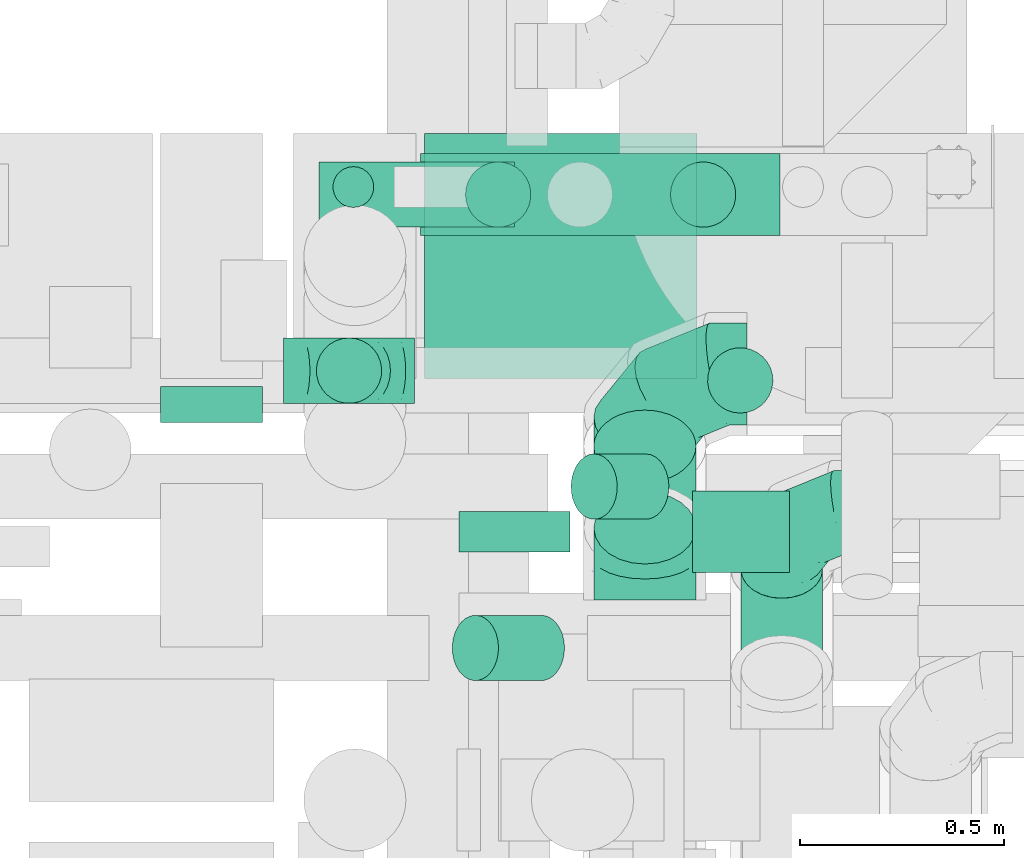
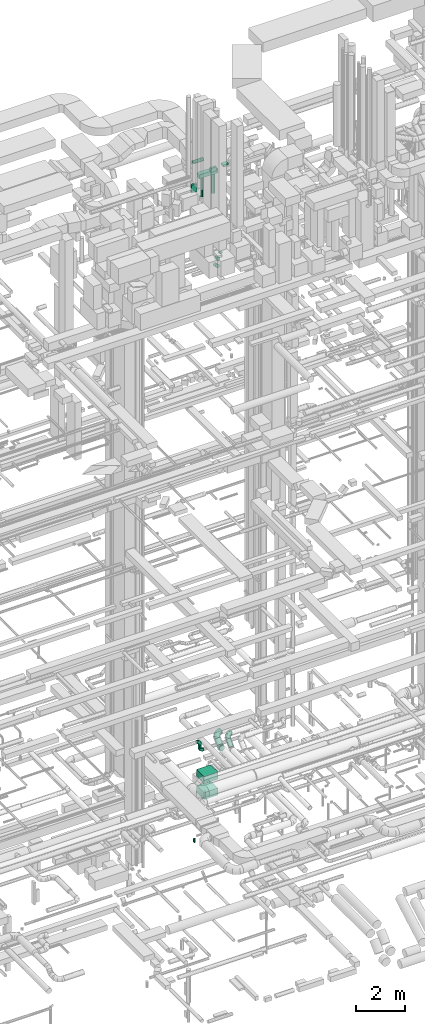
# One storey, part 189 of 337: 16 flow segments, 5 flow fittings.
"""IFC2X3 building model written with IfcOpenShell, lengths in millimetres."""

from ifc_helpers import new_model, entity, si_unit, converted_unit, derived_unit, direction, frame, origin, origin_2d_with_axis, place, context, subcontext, project, spatial, rectangle, circle, extrude, faceted_brep, source, transform, mapped, material, type_object, type_shapes, element, save


model = new_model("IFC2X3")

# Units and contexts
model_context = context("Model", 3, precision=0.01, world=origin(), true_north=direction((6.12303176911189e-17, 1.0)))
body_context = subcontext(model_context, "Body", "Model", "MODEL_VIEW")
ifc_project = project(units=[si_unit("LENGTHUNIT", "METRE", prefix="MILLI"), si_unit("AREAUNIT", "SQUARE_METRE"), si_unit("VOLUMEUNIT", "CUBIC_METRE"), converted_unit("PLANEANGLEUNIT", "DEGREE", entity("IfcRatioMeasure", 0.0174532925199433), si_unit("PLANEANGLEUNIT", "RADIAN"), dimensions=[0, 0, 0, 0, 0, 0, 0]), si_unit("MASSUNIT", "GRAM", prefix="KILO"), derived_unit("MASSDENSITYUNIT", [(si_unit("MASSUNIT", "GRAM", prefix="KILO"), 1), (si_unit("LENGTHUNIT", "METRE"), -3)]), derived_unit("MOMENTOFINERTIAUNIT", [(si_unit("LENGTHUNIT", "METRE"), 4)]), si_unit("TIMEUNIT", "SECOND"), si_unit("FREQUENCYUNIT", "HERTZ"), si_unit("THERMODYNAMICTEMPERATUREUNIT", "DEGREE_CELSIUS"), derived_unit("THERMALTRANSMITTANCEUNIT", [(si_unit("MASSUNIT", "GRAM", prefix="KILO"), 1), (si_unit("THERMODYNAMICTEMPERATUREUNIT", "KELVIN"), -1), (si_unit("TIMEUNIT", "SECOND"), -3)]), derived_unit("VOLUMETRICFLOWRATEUNIT", [(si_unit("LENGTHUNIT", "METRE"), 3), (si_unit("TIMEUNIT", "SECOND"), -1)]), derived_unit("MASSFLOWRATEUNIT", [(si_unit("MASSUNIT", "GRAM", prefix="KILO"), 1), (si_unit("TIMEUNIT", "SECOND"), -1)]), derived_unit("ROTATIONALFREQUENCYUNIT", [(si_unit("TIMEUNIT", "SECOND"), -1)]), si_unit("ELECTRICCURRENTUNIT", "AMPERE"), si_unit("ELECTRICVOLTAGEUNIT", "VOLT"), si_unit("POWERUNIT", "WATT"), si_unit("FORCEUNIT", "NEWTON", prefix="KILO"), si_unit("ILLUMINANCEUNIT", "LUX"), si_unit("LUMINOUSFLUXUNIT", "LUMEN"), si_unit("LUMINOUSINTENSITYUNIT", "CANDELA"), derived_unit("USERDEFINED", [(si_unit("MASSUNIT", "GRAM", prefix="KILO"), -1), (si_unit("LENGTHUNIT", "METRE"), -2), (si_unit("TIMEUNIT", "SECOND"), 3), (si_unit("LUMINOUSFLUXUNIT", "LUMEN"), 1)]), derived_unit("LINEARVELOCITYUNIT", [(si_unit("LENGTHUNIT", "METRE"), 1), (si_unit("TIMEUNIT", "SECOND"), -1)]), si_unit("PRESSUREUNIT", "PASCAL"), derived_unit("USERDEFINED", [(si_unit("LENGTHUNIT", "METRE"), -2), (si_unit("MASSUNIT", "GRAM", prefix="KILO"), 1), (si_unit("TIMEUNIT", "SECOND"), -2)]), derived_unit("LINEARFORCEUNIT", [(si_unit("MASSUNIT", "GRAM", prefix="KILO"), 1), (si_unit("LENGTHUNIT", "METRE"), 1), (si_unit("TIMEUNIT", "SECOND"), -2), (si_unit("LENGTHUNIT", "METRE"), -1)]), derived_unit("PLANARFORCEUNIT", [(si_unit("MASSUNIT", "GRAM", prefix="KILO"), 1), (si_unit("LENGTHUNIT", "METRE"), 1), (si_unit("TIMEUNIT", "SECOND"), -2), (si_unit("LENGTHUNIT", "METRE"), -2)])], contexts=[model_context])

# Site, building, storey
site_placement = place(None, origin())
site = spatial("IfcSite", under=ifc_project, at=site_placement, CompositionType="ELEMENT")
building_placement = place(site_placement, origin())
building = spatial("IfcBuilding", under=site, at=building_placement, CompositionType="ELEMENT")
storey_placement = place(building_placement, origin())
storey = spatial("IfcBuildingStorey", under=building, at=storey_placement, CompositionType="ELEMENT", Elevation=0.0)

# Flow segments
duct_segment_type_1 = type_object("IfcDuctSegmentType", PredefinedType="NOTDEFINED")
for number, where in (
    (1, (49187.58, 12574.75, 300.06)),
    (2, (49187.58, 12574.75, 1100.06)),
):
    element("IfcFlowSegment", number, at=place(storey_placement, frame(where)), inside=storey, type_object=duct_segment_type_1, context=body_context, shape_type="SweptSolid", body=[
        extrude(rectangle(XDim=666.974171799962, YDim=600.0, at=origin_2d_with_axis()), frame((333.49, 300.0, 0.0), z_axis=(0.0, 0.0, 1.0), x_axis=(-1.0, 0.0, 0.0)), (0.0, 0.0, 1.0), 350.0),
    ])
flow_segment_1_placement = place(storey_placement, frame((49178.28, 12924.99, 30999.32)))
element("IfcFlowSegment", 3, at=flow_segment_1_placement, inside=storey, type_object=duct_segment_type_1, context=body_context, shape_type="SweptSolid", body=[
    extrude(rectangle(XDim=879.999999999939, YDim=200.0, at=origin_2d_with_axis()), frame((440.0, 100.0, 0.0), z_axis=(0.0, 0.0, 1.0), x_axis=(-1.0, 0.0, 0.0)), (0.0, 0.0, 1.0), 199.999999999998),
])
flow_segment_2_placement = place(storey_placement, frame((48542.04, 12467.5, 30780.0)))
element("IfcFlowSegment", 4, at=flow_segment_2_placement, inside=storey, type_object=duct_segment_type_1, context=body_context, shape_type="SweptSolid", body=[
    extrude(rectangle(XDim=87.2484350000335, YDim=250.000000000004, at=origin_2d_with_axis()), frame((125.0, 43.62, 0.0), z_axis=(0.0, 0.0, 1.0), x_axis=(0.0, -1.0, 0.0)), (0.0, 0.0, 1.0), 400.000000000004),
])
flow_segment_3_placement = place(storey_placement, frame((49273.0, 12149.48, 31750.0)))
element("IfcFlowSegment", 5, at=flow_segment_3_placement, inside=storey, type_object=duct_segment_type_1, context=body_context, shape_type="SweptSolid", body=[
    extrude(rectangle(XDim=271.034502525399, YDim=100.000000000001, at=origin_2d_with_axis()), frame((135.52, 50.0, 0.0)), (0.0, 0.0, 1.0), 199.999999999998),
])
flow_segment_4_placement = place(storey_placement, frame((49844.03, 12099.48, 31850.0)))
element("IfcFlowSegment", 6, at=flow_segment_4_placement, inside=storey, type_object=duct_segment_type_1, context=body_context, shape_type="SweptSolid", body=[
    extrude(rectangle(XDim=237.021317421704, YDim=200.0, at=origin_2d_with_axis()), frame((118.51, 100.0, 0.0), z_axis=(0.0, 0.0, 1.0), x_axis=(-1.0, 0.0, 0.0)), (0.0, 0.0, 1.0), 100.000000000003),
])
duct_segment_type_2 = type_object("IfcDuctSegmentType", PredefinedType="NOTDEFINED")
flow_segment_5_placement = place(storey_placement, frame((49545.32, 12228.45, 27128.7)))
element("IfcFlowSegment", 7, at=flow_segment_5_placement, inside=storey, type_object=duct_segment_type_2, context=body_context, shape_type="SweptSolid", body=[
    extrude(circle(Radius=80.0, at=origin_2d_with_axis()), frame((184.44, 81.6, 58.16), z_axis=(-0.707106781186541, 0.0, 0.707106781186554), x_axis=(0.0, 1.0, 0.0)), (0.0, 0.0, 1.0), 178.578643762692),
])
flow_segment_6_placement = place(storey_placement, frame((49254.49, 11833.6, 27103.41)))
element("IfcFlowSegment", 8, at=flow_segment_6_placement, inside=storey, type_object=duct_segment_type_2, context=body_context, shape_type="SweptSolid", body=[
    extrude(circle(Radius=80.0, at=origin_2d_with_axis()), frame((219.73, 81.6, 58.16), z_axis=(-0.707106781186536, 0.0, 0.70710678118656), x_axis=(0.0, 1.0, 0.0)), (0.0, 0.0, 1.0), 228.490691502432),
])
flow_segment_7_placement = place(storey_placement, frame((49879.49, 12488.5, 27280.0)))
element("IfcFlowSegment", 9, at=flow_segment_7_placement, inside=storey, type_object=duct_segment_type_2, context=body_context, shape_type="SweptSolid", body=[
    extrude(circle(Radius=80.0, at=origin_2d_with_axis()), frame((81.6, 81.6, 0.0), z_axis=(0.0, 0.0, 1.0), x_axis=(0.0, -1.0, 0.0)), (0.0, 0.0, 1.0), 9.99999999999773),
])
for number, where in (
    (10, (49286.87, 12943.39, 30019.32)),
    (11, (49788.51, 12943.39, 30019.32)),
):
    element("IfcFlowSegment", number, at=place(storey_placement, frame(where)), inside=storey, type_object=duct_segment_type_2, context=body_context, shape_type="SweptSolid", body=[
        extrude(circle(Radius=80.0, at=origin_2d_with_axis()), frame((81.6, 81.6, 0.0), z_axis=(0.0, 0.0, 1.0), x_axis=(-1.0, 0.0, 0.0)), (0.0, 0.0, 1.0), 959.99999999986),
    ])
flow_segment_8_placement = place(storey_placement, frame((48930.09, 12943.39, 31768.4)))
element("IfcFlowSegment", 12, at=flow_segment_8_placement, inside=storey, type_object=duct_segment_type_2, context=body_context, shape_type="SweptSolid", body=[
    extrude(circle(Radius=80.0, at=origin_2d_with_axis()), frame((0.0, 81.6, 81.6), z_axis=(1.0, 0.0, 0.0), x_axis=(0.0, 1.0, 0.0)), (0.0, 0.0, 1.0), 478.54134000003),
])
flow_segment_9_placement = place(storey_placement, frame((48921.74, 12512.32, 2980.0)))
element("IfcFlowSegment", 13, at=flow_segment_9_placement, inside=storey, type_object=duct_segment_type_2, context=body_context, shape_type="SweptSolid", body=[
    extrude(circle(Radius=80.0, at=origin_2d_with_axis()), frame((81.6, 81.6, 0.0), z_axis=(0.0, 0.0, 1.0), x_axis=(0.0, 1.0, 0.0)), (0.0, 0.0, 1.0), 140.000000000007),
])
flow_segment_10_placement = place(storey_placement, frame((49600.95, 12119.0, 2983.24)))
element("IfcFlowSegment", 14, at=flow_segment_10_placement, inside=storey, type_object=duct_segment_type_2, context=body_context, shape_type="SweptSolid", body=[
    extrude(circle(Radius=125.0, at=origin_2d_with_axis()), frame((126.6, 89.98, 89.98), z_axis=(0.0, 0.707106781186547, 0.707106781186548), x_axis=(1.0, 0.0, 0.0)), (0.0, 0.0, 1.0), 282.842712474678),
])
flow_segment_11_placement = place(storey_placement, frame((49960.95, 11785.31, 2986.27)))
element("IfcFlowSegment", 15, at=flow_segment_11_placement, inside=storey, type_object=duct_segment_type_2, context=body_context, shape_type="SweptSolid", body=[
    extrude(circle(Radius=100.0, at=origin_2d_with_axis()), frame((101.6, 72.31, 72.31), z_axis=(0.0, 0.707106781186548, 0.707106781186548), x_axis=(-1.0, 0.0, 0.0)), (0.0, 0.0, 1.0), 353.553390593291),
])
flow_segment_12_placement = place(storey_placement, frame((48962.41, 12991.81, -2030.0)))
element("IfcFlowSegment", 16, at=flow_segment_12_placement, inside=storey, type_object=duct_segment_type_2, context=body_context, shape_type="SweptSolid", body=[
    extrude(circle(Radius=50.0, at=origin_2d_with_axis()), frame((51.6, 51.6, 0.0), z_axis=(0.0, 0.0, 1.0), x_axis=(0.0, 1.0, 0.0)), (0.0, 0.0, 1.0), 180.000000000009),
])

# Flow fittings
ifc_material = material()
duct_fitting_type_1 = type_object("IfcDuctFittingType", PredefinedType="NOTDEFINED", material=ifc_material)
shared_shape_1 = source(origin(), body_context, "Body", "Brep", [
    faceted_brep([(-160.0, 0.0, -80.0), (-160.0, -20.71, -77.27), (-160.0, -40.0, -69.28), (-160.0, -56.57, -56.57), (-160.0, -69.28, -40.0), (-160.0, -77.27, -20.71), (-160.0, -80.0, 0.0), (-160.0, -77.27, 20.71), (-160.0, -69.28, 40.0), (-160.0, -56.57, 56.57), (-160.0, -40.0, 69.28), (-160.0, -20.71, 77.27), (-160.0, 0.0, 80.0), (-160.0, 20.71, 77.27), (-160.0, 40.0, 69.28), (-160.0, 56.57, 56.57), (-160.0, 69.28, 40.0), (-160.0, 77.27, 20.71), (-160.0, 80.0, 0.0), (-160.0, 77.27, -20.71), (-160.0, 69.28, -40.0), (-160.0, 56.57, -56.57), (-160.0, 40.0, -69.28), (-160.0, 20.71, -77.27), (-122.68, 20.71, 77.27), (-127.85, 40.0, 69.28), (-117.13, 0.0, 80.0), (-132.29, 56.57, 56.57), (-137.83, 77.27, 20.71), (-138.56, 80.0, 0.0), (-135.69, 69.28, 40.0), (-135.69, 69.28, -40.0), (-132.29, 56.57, -56.57), (-137.83, 77.27, -20.71), (-122.68, 20.71, -77.27), (-117.13, 0.0, -80.0), (-127.85, 40.0, -69.28), (-111.58, -20.71, -77.27), (-106.41, -40.0, -69.28), (-101.97, -56.57, -56.57), (-98.56, -69.28, -40.0), (-96.42, -77.27, -20.71), (-95.69, -80.0, 0.0), (-96.42, -77.27, 20.71), (-98.56, -69.28, 40.0), (-101.97, -56.57, 56.57), (-106.41, -40.0, 69.28), (-111.58, -20.71, 77.27), (-58.03, 58.03, 77.27), (-72.15, 72.15, 69.28), (-42.87, 42.87, 80.0), (-84.28, 84.28, 56.57), (-93.59, 93.59, 40.0), (-99.44, 99.44, 20.71), (-101.44, 101.44, 0.0), (-99.44, 99.44, -20.71), (-93.59, 93.59, -40.0), (-84.28, 84.28, -56.57), (-58.03, 58.03, -77.27), (-42.87, 42.87, -80.0), (-72.15, 72.15, -69.28), (-27.71, 27.71, -77.27), (-13.59, 13.59, -69.28), (-1.46, 1.46, -56.57), (7.85, -7.85, -40.0), (13.7, -13.7, -20.71), (15.69, -15.69, 0.0), (13.7, -13.7, 20.71), (7.85, -7.85, 40.0), (-1.46, 1.46, 56.57), (-13.59, 13.59, 69.28), (-27.71, 27.71, 77.27), (-20.71, 122.68, 77.27), (-40.0, 127.85, 69.28), (0.0, 117.13, 80.0), (-56.57, 132.29, 56.57), (-69.28, 135.69, 40.0), (-77.27, 137.83, 20.71), (-80.0, 138.56, 0.0), (-77.27, 137.83, -20.71), (-69.28, 135.69, -40.0), (-56.57, 132.29, -56.57), (-20.71, 122.68, -77.27), (0.0, 117.13, -80.0), (-40.0, 127.85, -69.28), (20.71, 111.58, -77.27), (40.0, 106.41, -69.28), (56.57, 101.97, -56.57), (69.28, 98.56, -40.0), (77.27, 96.42, -20.71), (80.0, 95.69, 0.0), (77.27, 96.42, 20.71), (69.28, 98.56, 40.0), (56.57, 101.97, 56.57), (40.0, 106.41, 69.28), (20.71, 111.58, 77.27), (-20.71, 160.0, -77.27), (-40.0, 160.0, -69.28), (-56.57, 160.0, -56.57), (-69.28, 160.0, -40.0), (-77.27, 160.0, -20.71), (-80.0, 160.0, 0.0), (-77.27, 160.0, 20.71), (-69.28, 160.0, 40.0), (-56.57, 160.0, 56.57), (-40.0, 160.0, 69.28), (-20.71, 160.0, 77.27), (0.0, 160.0, 80.0), (20.71, 160.0, 77.27), (40.0, 160.0, 69.28), (56.57, 160.0, 56.57), (69.28, 160.0, 40.0), (77.27, 160.0, 20.71), (80.0, 160.0, 0.0), (77.27, 160.0, -20.71), (69.28, 160.0, -40.0), (56.57, 160.0, -56.57), (40.0, 160.0, -69.28), (20.71, 160.0, -77.27), (0.0, 160.0, -80.0)], [[[0, 1, 2, 3, 4, 5, 6, 7, 8, 9, 10, 11, 12, 13, 14, 15, 16, 17, 18, 19, 20, 21, 22, 23]], [[24, 25, 14, 13]], [[26, 24, 13, 12]], [[14, 25, 27, 15]], [[28, 29, 18, 17]], [[30, 28, 17, 16]], [[15, 27, 30, 16]], [[20, 31, 32, 21]], [[33, 31, 20, 19]], [[18, 29, 33, 19]], [[34, 35, 0, 23]], [[36, 34, 23, 22]], [[32, 36, 22, 21]], [[1, 0, 35, 37]], [[2, 1, 37, 38]], [[3, 2, 38, 39]], [[5, 4, 40, 41]], [[6, 5, 41, 42]], [[39, 40, 4, 3]], [[6, 42, 43, 7]], [[7, 43, 44, 8]], [[8, 44, 45, 9]], [[9, 45, 46, 10]], [[10, 46, 47, 11]], [[26, 12, 11, 47]], [[48, 49, 25, 24]], [[50, 48, 24, 26]], [[27, 25, 49, 51]], [[52, 53, 28, 30]], [[51, 52, 30, 27]], [[29, 28, 53, 54]], [[55, 56, 31, 33]], [[54, 55, 33, 29]], [[32, 31, 56, 57]], [[58, 59, 35, 34]], [[60, 58, 34, 36]], [[57, 60, 36, 32]], [[37, 35, 59, 61]], [[38, 37, 61, 62]], [[39, 38, 62, 63]], [[41, 40, 64, 65]], [[42, 41, 65, 66]], [[63, 64, 40, 39]], [[43, 42, 66, 67]], [[44, 43, 67, 68]], [[68, 69, 45, 44]], [[46, 45, 69, 70]], [[47, 46, 70, 71]], [[26, 47, 71, 50]], [[72, 73, 49, 48]], [[74, 72, 48, 50]], [[51, 49, 73, 75]], [[76, 77, 53, 52]], [[75, 76, 52, 51]], [[54, 53, 77, 78]], [[79, 80, 56, 55]], [[78, 79, 55, 54]], [[57, 56, 80, 81]], [[82, 83, 59, 58]], [[84, 82, 58, 60]], [[81, 84, 60, 57]], [[61, 59, 83, 85]], [[62, 61, 85, 86]], [[63, 62, 86, 87]], [[65, 64, 88, 89]], [[66, 65, 89, 90]], [[87, 88, 64, 63]], [[67, 66, 90, 91]], [[68, 67, 91, 92]], [[92, 93, 69, 68]], [[70, 69, 93, 94]], [[71, 70, 94, 95]], [[50, 71, 95, 74]], [[96, 97, 98, 99, 100, 101, 102, 103, 104, 105, 106, 107, 108, 109, 110, 111, 112, 113, 114, 115, 116, 117, 118, 119]], [[72, 74, 107, 106]], [[73, 72, 106, 105]], [[75, 73, 105, 104]], [[77, 76, 103, 102]], [[78, 77, 102, 101]], [[75, 104, 103, 76]], [[78, 101, 100, 79]], [[79, 100, 99, 80]], [[80, 99, 98, 81]], [[84, 97, 96, 82]], [[82, 96, 119, 83]], [[84, 81, 98, 97]], [[118, 117, 86, 85]], [[119, 118, 85, 83]], [[116, 87, 86, 117]], [[88, 115, 114, 89]], [[89, 114, 113, 90]], [[115, 88, 87, 116]], [[112, 111, 92, 91]], [[113, 112, 91, 90]], [[111, 110, 93, 92]], [[95, 94, 109, 108]], [[74, 95, 108, 107]], [[110, 109, 94, 93]]]),
])
type_shapes(duct_fitting_type_1, [shared_shape_1])
for number, where, z_axis, x_axis in (
    (17, (49003.34, 12593.92, 3280.0), (0.0, 1.0, 0.0), (1.0, 0.0, 0.0)),
    (18, (49003.34, 12593.92, 2820.0), (0.0, -1.0, 0.0), (0.0, 0.0, -1.0)),
):
    element("IfcFlowFitting", number, at=place(storey_placement, frame(where, z_axis=z_axis, x_axis=x_axis)), inside=storey, type_object=duct_fitting_type_1, material=ifc_material, context=body_context, shape_type="MappedRepresentation", body=[
        mapped(shared_shape_1, transform((0.0, 0.0, 0.0), scale=1.0)),
    ])
duct_fitting_type_2 = type_object("IfcDuctFittingType", PredefinedType="NOTDEFINED", material=ifc_material)
shared_shape_2 = source(origin(), body_context, "Body", "Brep", [
    faceted_brep([(-250.0, 0.0, -125.0), (-250.0, -32.35, -120.74), (-250.0, -62.5, -108.25), (-250.0, -88.39, -88.39), (-250.0, -108.25, -62.5), (-250.0, -120.74, -32.35), (-250.0, -125.0, 0.0), (-250.0, -120.74, 32.35), (-250.0, -108.25, 62.5), (-250.0, -88.39, 88.39), (-250.0, -62.5, 108.25), (-250.0, -32.35, 120.74), (-250.0, 0.0, 125.0), (-250.0, 32.35, 120.74), (-250.0, 62.5, 108.25), (-250.0, 88.39, 88.39), (-250.0, 108.25, 62.5), (-250.0, 120.74, 32.35), (-250.0, 125.0, 0.0), (-250.0, 120.74, -32.35), (-250.0, 108.25, -62.5), (-250.0, 88.39, -88.39), (-250.0, 62.5, -108.25), (-250.0, 32.35, -120.74), (-191.68, 32.35, 120.74), (-199.76, 62.5, 108.25), (-183.01, 0.0, 125.0), (-206.7, 88.39, 88.39), (-215.37, 120.74, 32.35), (-216.51, 125.0, 0.0), (-212.02, 108.25, 62.5), (-212.02, 108.25, -62.5), (-206.7, 88.39, -88.39), (-215.37, 120.74, -32.35), (-191.68, 32.35, -120.74), (-183.01, 0.0, -125.0), (-199.76, 62.5, -108.25), (-174.34, -32.35, -120.74), (-166.27, -62.5, -108.25), (-159.33, -88.39, -88.39), (-154.01, -108.25, -62.5), (-150.66, -120.74, -32.35), (-149.52, -125.0, 0.0), (-150.66, -120.74, 32.35), (-154.01, -108.25, 62.5), (-159.33, -88.39, 88.39), (-166.27, -62.5, 108.25), (-174.34, -32.35, 120.74), (-90.67, 90.67, 120.74), (-112.74, 112.74, 108.25), (-66.99, 66.99, 125.0), (-131.69, 131.69, 88.39), (-146.23, 146.23, 62.5), (-155.38, 155.38, 32.35), (-158.49, 158.49, 0.0), (-155.38, 155.38, -32.35), (-146.23, 146.23, -62.5), (-131.69, 131.69, -88.39), (-90.67, 90.67, -120.74), (-66.99, 66.99, -125.0), (-112.74, 112.74, -108.25), (-43.3, 43.3, -120.74), (-21.23, 21.23, -108.25), (-2.28, 2.28, -88.39), (12.26, -12.26, -62.5), (21.4, -21.4, -32.35), (24.52, -24.52, 0.0), (21.4, -21.4, 32.35), (12.26, -12.26, 62.5), (-2.28, 2.28, 88.39), (-21.23, 21.23, 108.25), (-43.3, 43.3, 120.74), (-32.35, 191.68, 120.74), (-62.5, 199.76, 108.25), (0.0, 183.01, 125.0), (-88.39, 206.7, 88.39), (-108.25, 212.02, 62.5), (-120.74, 215.37, 32.35), (-125.0, 216.51, 0.0), (-120.74, 215.37, -32.35), (-108.25, 212.02, -62.5), (-88.39, 206.7, -88.39), (-32.35, 191.68, -120.74), (0.0, 183.01, -125.0), (-62.5, 199.76, -108.25), (32.35, 174.34, -120.74), (62.5, 166.27, -108.25), (88.39, 159.33, -88.39), (108.25, 154.01, -62.5), (120.74, 150.66, -32.35), (125.0, 149.52, 0.0), (120.74, 150.66, 32.35), (108.25, 154.01, 62.5), (88.39, 159.33, 88.39), (62.5, 166.27, 108.25), (32.35, 174.34, 120.74), (-32.35, 250.0, -120.74), (-62.5, 250.0, -108.25), (-88.39, 250.0, -88.39), (-108.25, 250.0, -62.5), (-120.74, 250.0, -32.35), (-125.0, 250.0, 0.0), (-120.74, 250.0, 32.35), (-108.25, 250.0, 62.5), (-88.39, 250.0, 88.39), (-62.5, 250.0, 108.25), (-32.35, 250.0, 120.74), (0.0, 250.0, 125.0), (32.35, 250.0, 120.74), (62.5, 250.0, 108.25), (88.39, 250.0, 88.39), (108.25, 250.0, 62.5), (120.74, 250.0, 32.35), (125.0, 250.0, 0.0), (120.74, 250.0, -32.35), (108.25, 250.0, -62.5), (88.39, 250.0, -88.39), (62.5, 250.0, -108.25), (32.35, 250.0, -120.74), (0.0, 250.0, -125.0)], [[[0, 1, 2, 3, 4, 5, 6, 7, 8, 9, 10, 11, 12, 13, 14, 15, 16, 17, 18, 19, 20, 21, 22, 23]], [[24, 25, 14, 13]], [[26, 24, 13, 12]], [[14, 25, 27, 15]], [[28, 29, 18, 17]], [[30, 28, 17, 16]], [[15, 27, 30, 16]], [[20, 31, 32, 21]], [[33, 31, 20, 19]], [[18, 29, 33, 19]], [[34, 35, 0, 23]], [[36, 34, 23, 22]], [[21, 32, 36, 22]], [[1, 0, 35, 37]], [[2, 1, 37, 38]], [[38, 39, 3, 2]], [[5, 4, 40, 41]], [[6, 5, 41, 42]], [[39, 40, 4, 3]], [[6, 42, 43, 7]], [[7, 43, 44, 8]], [[8, 44, 45, 9]], [[9, 45, 46, 10]], [[10, 46, 47, 11]], [[26, 12, 11, 47]], [[48, 49, 25, 24]], [[50, 48, 24, 26]], [[27, 25, 49, 51]], [[52, 53, 28, 30]], [[51, 52, 30, 27]], [[29, 28, 53, 54]], [[55, 56, 31, 33]], [[54, 55, 33, 29]], [[32, 31, 56, 57]], [[58, 59, 35, 34]], [[60, 58, 34, 36]], [[57, 60, 36, 32]], [[37, 35, 59, 61]], [[38, 37, 61, 62]], [[39, 38, 62, 63]], [[41, 40, 64, 65]], [[42, 41, 65, 66]], [[63, 64, 40, 39]], [[43, 42, 66, 67]], [[44, 43, 67, 68]], [[68, 69, 45, 44]], [[46, 45, 69, 70]], [[47, 46, 70, 71]], [[26, 47, 71, 50]], [[72, 73, 49, 48]], [[74, 72, 48, 50]], [[51, 49, 73, 75]], [[76, 77, 53, 52]], [[75, 76, 52, 51]], [[54, 53, 77, 78]], [[79, 80, 56, 55]], [[78, 79, 55, 54]], [[57, 56, 80, 81]], [[82, 83, 59, 58]], [[84, 82, 58, 60]], [[81, 84, 60, 57]], [[61, 59, 83, 85]], [[62, 61, 85, 86]], [[63, 62, 86, 87]], [[65, 64, 88, 89]], [[66, 65, 89, 90]], [[87, 88, 64, 63]], [[67, 66, 90, 91]], [[68, 67, 91, 92]], [[92, 93, 69, 68]], [[70, 69, 93, 94]], [[71, 70, 94, 95]], [[50, 71, 95, 74]], [[96, 97, 98, 99, 100, 101, 102, 103, 104, 105, 106, 107, 108, 109, 110, 111, 112, 113, 114, 115, 116, 117, 118, 119]], [[72, 74, 107, 106]], [[73, 72, 106, 105]], [[75, 73, 105, 104]], [[77, 76, 103, 102]], [[78, 77, 102, 101]], [[75, 104, 103, 76]], [[78, 101, 100, 79]], [[79, 100, 99, 80]], [[80, 99, 98, 81]], [[84, 97, 96, 82]], [[82, 96, 119, 83]], [[84, 81, 98, 97]], [[83, 119, 118, 85]], [[85, 118, 117, 86]], [[116, 87, 86, 117]], [[88, 115, 114, 89]], [[89, 114, 113, 90]], [[115, 88, 87, 116]], [[91, 90, 113, 112]], [[92, 91, 112, 111]], [[111, 110, 93, 92]], [[95, 94, 109, 108]], [[74, 95, 108, 107]], [[110, 109, 94, 93]]]),
])
type_shapes(duct_fitting_type_2, [shared_shape_2])
flow_fitting_1_placement = place(storey_placement, frame((49727.54, 12585.76, 3450.0), z_axis=(0.0, -0.707106781186571, 0.707106781186524), x_axis=(-1.0, 0.0, 0.0)))
element("IfcFlowFitting", 19, at=flow_fitting_1_placement, inside=storey, type_object=duct_fitting_type_2, material=ifc_material, context=body_context, shape_type="MappedRepresentation", body=[
    mapped(shared_shape_2, transform((0.0, 0.0, 0.0), scale=1.0)),
])
duct_fitting_type_3 = type_object("IfcDuctFittingType", PredefinedType="NOTDEFINED", material=ifc_material)
shared_shape_3 = source(origin(), body_context, "Body", "Brep", [
    faceted_brep([(-200.0, 0.0, -100.0), (-200.0, -25.88, -96.59), (-200.0, -50.0, -86.6), (-200.0, -70.71, -70.71), (-200.0, -86.6, -50.0), (-200.0, -96.59, -25.88), (-200.0, -100.0, 0.0), (-200.0, -96.59, 25.88), (-200.0, -86.6, 50.0), (-200.0, -70.71, 70.71), (-200.0, -50.0, 86.6), (-200.0, -25.88, 96.59), (-200.0, 0.0, 100.0), (-200.0, 25.88, 96.59), (-200.0, 50.0, 86.6), (-200.0, 70.71, 70.71), (-200.0, 86.6, 50.0), (-200.0, 96.59, 25.88), (-200.0, 100.0, 0.0), (-200.0, 96.59, -25.88), (-200.0, 86.6, -50.0), (-200.0, 70.71, -70.71), (-200.0, 50.0, -86.6), (-200.0, 25.88, -96.59), (-153.35, 25.88, 96.59), (-159.81, 50.0, 86.6), (-146.41, 0.0, 100.0), (-165.36, 70.71, 70.71), (-172.29, 96.59, 25.88), (-173.21, 100.0, 0.0), (-169.62, 86.6, 50.0), (-169.62, 86.6, -50.0), (-165.36, 70.71, -70.71), (-172.29, 96.59, -25.88), (-153.35, 25.88, -96.59), (-146.41, 0.0, -100.0), (-159.81, 50.0, -86.6), (-139.48, -25.88, -96.59), (-133.01, -50.0, -86.6), (-127.46, -70.71, -70.71), (-123.21, -86.6, -50.0), (-120.53, -96.59, -25.88), (-119.62, -100.0, 0.0), (-120.53, -96.59, 25.88), (-123.21, -86.6, 50.0), (-127.46, -70.71, 70.71), (-133.01, -50.0, 86.6), (-139.48, -25.88, 96.59), (-72.54, 72.54, 96.59), (-90.19, 90.19, 86.6), (-53.59, 53.59, 100.0), (-105.35, 105.35, 70.71), (-116.99, 116.99, 50.0), (-124.3, 124.3, 25.88), (-126.79, 126.79, 0.0), (-124.3, 124.3, -25.88), (-116.99, 116.99, -50.0), (-105.35, 105.35, -70.71), (-72.54, 72.54, -96.59), (-53.59, 53.59, -100.0), (-90.19, 90.19, -86.6), (-34.64, 34.64, -96.59), (-16.99, 16.99, -86.6), (-1.83, 1.83, -70.71), (9.81, -9.81, -50.0), (17.12, -17.12, -25.88), (19.62, -19.62, 0.0), (17.12, -17.12, 25.88), (9.81, -9.81, 50.0), (-1.83, 1.83, 70.71), (-16.99, 16.99, 86.6), (-34.64, 34.64, 96.59), (-25.88, 153.35, 96.59), (-50.0, 159.81, 86.6), (0.0, 146.41, 100.0), (-70.71, 165.36, 70.71), (-86.6, 169.62, 50.0), (-96.59, 172.29, 25.88), (-100.0, 173.21, 0.0), (-96.59, 172.29, -25.88), (-86.6, 169.62, -50.0), (-70.71, 165.36, -70.71), (-25.88, 153.35, -96.59), (0.0, 146.41, -100.0), (-50.0, 159.81, -86.6), (25.88, 139.48, -96.59), (50.0, 133.01, -86.6), (70.71, 127.46, -70.71), (86.6, 123.21, -50.0), (96.59, 120.53, -25.88), (100.0, 119.62, 0.0), (96.59, 120.53, 25.88), (86.6, 123.21, 50.0), (70.71, 127.46, 70.71), (50.0, 133.01, 86.6), (25.88, 139.48, 96.59), (-25.88, 200.0, -96.59), (-50.0, 200.0, -86.6), (-70.71, 200.0, -70.71), (-86.6, 200.0, -50.0), (-96.59, 200.0, -25.88), (-100.0, 200.0, 0.0), (-96.59, 200.0, 25.88), (-86.6, 200.0, 50.0), (-70.71, 200.0, 70.71), (-50.0, 200.0, 86.6), (-25.88, 200.0, 96.59), (0.0, 200.0, 100.0), (25.88, 200.0, 96.59), (50.0, 200.0, 86.6), (70.71, 200.0, 70.71), (86.6, 200.0, 50.0), (96.59, 200.0, 25.88), (100.0, 200.0, 0.0), (96.59, 200.0, -25.88), (86.6, 200.0, -50.0), (70.71, 200.0, -70.71), (50.0, 200.0, -86.6), (25.88, 200.0, -96.59), (0.0, 200.0, -100.0)], [[[0, 1, 2, 3, 4, 5, 6, 7, 8, 9, 10, 11, 12, 13, 14, 15, 16, 17, 18, 19, 20, 21, 22, 23]], [[24, 25, 14, 13]], [[26, 24, 13, 12]], [[14, 25, 27, 15]], [[28, 29, 18, 17]], [[30, 28, 17, 16]], [[15, 27, 30, 16]], [[20, 31, 32, 21]], [[33, 31, 20, 19]], [[18, 29, 33, 19]], [[34, 35, 0, 23]], [[36, 34, 23, 22]], [[32, 36, 22, 21]], [[1, 0, 35, 37]], [[2, 1, 37, 38]], [[38, 39, 3, 2]], [[5, 4, 40, 41]], [[6, 5, 41, 42]], [[39, 40, 4, 3]], [[6, 42, 43, 7]], [[7, 43, 44, 8]], [[8, 44, 45, 9]], [[9, 45, 46, 10]], [[10, 46, 47, 11]], [[26, 12, 11, 47]], [[48, 49, 25, 24]], [[50, 48, 24, 26]], [[27, 25, 49, 51]], [[52, 53, 28, 30]], [[51, 52, 30, 27]], [[29, 28, 53, 54]], [[55, 56, 31, 33]], [[54, 55, 33, 29]], [[32, 31, 56, 57]], [[58, 59, 35, 34]], [[60, 58, 34, 36]], [[57, 60, 36, 32]], [[37, 35, 59, 61]], [[38, 37, 61, 62]], [[39, 38, 62, 63]], [[41, 40, 64, 65]], [[42, 41, 65, 66]], [[63, 64, 40, 39]], [[43, 42, 66, 67]], [[44, 43, 67, 68]], [[68, 69, 45, 44]], [[46, 45, 69, 70]], [[47, 46, 70, 71]], [[26, 47, 71, 50]], [[72, 73, 49, 48]], [[74, 72, 48, 50]], [[51, 49, 73, 75]], [[76, 77, 53, 52]], [[75, 76, 52, 51]], [[54, 53, 77, 78]], [[79, 80, 56, 55]], [[78, 79, 55, 54]], [[57, 56, 80, 81]], [[82, 83, 59, 58]], [[84, 82, 58, 60]], [[81, 84, 60, 57]], [[61, 59, 83, 85]], [[62, 61, 85, 86]], [[63, 62, 86, 87]], [[65, 64, 88, 89]], [[66, 65, 89, 90]], [[87, 88, 64, 63]], [[67, 66, 90, 91]], [[68, 67, 91, 92]], [[92, 93, 69, 68]], [[70, 69, 93, 94]], [[71, 70, 94, 95]], [[50, 71, 95, 74]], [[96, 97, 98, 99, 100, 101, 102, 103, 104, 105, 106, 107, 108, 109, 110, 111, 112, 113, 114, 115, 116, 117, 118, 119]], [[72, 74, 107, 106]], [[73, 72, 106, 105]], [[75, 73, 105, 104]], [[102, 101, 78, 77]], [[103, 102, 77, 76]], [[75, 104, 103, 76]], [[78, 101, 100, 79]], [[79, 100, 99, 80]], [[80, 99, 98, 81]], [[84, 97, 96, 82]], [[82, 96, 119, 83]], [[84, 81, 98, 97]], [[118, 117, 86, 85]], [[119, 118, 85, 83]], [[116, 87, 86, 117]], [[88, 115, 114, 89]], [[89, 114, 113, 90]], [[115, 88, 87, 116]], [[91, 90, 113, 112]], [[92, 91, 112, 111]], [[111, 110, 93, 92]], [[95, 94, 109, 108]], [[74, 95, 108, 107]], [[110, 109, 94, 93]]]),
])
type_shapes(duct_fitting_type_3, [shared_shape_3])
flow_fitting_2_placement = place(storey_placement, frame((50062.54, 12249.04, 3450.0), z_axis=(0.0, -0.707106781186548, 0.707106781186547), x_axis=(-1.0, 0.0, 0.0)))
element("IfcFlowFitting", 20, at=flow_fitting_2_placement, inside=storey, type_object=duct_fitting_type_3, material=ifc_material, context=body_context, shape_type="MappedRepresentation", body=[
    mapped(shared_shape_3, transform((0.0, 0.0, 0.0), scale=1.0)),
])
duct_fitting_type_4 = type_object("IfcDuctFittingType", PredefinedType="NOTDEFINED", material=ifc_material)
shared_shape_4 = source(origin(), body_context, "Body", "Brep", [
    faceted_brep([(-103.55, 0.0, -125.0), (-103.55, -32.35, -120.74), (-103.55, -62.5, -108.25), (-103.55, -88.39, -88.39), (-103.55, -108.25, -62.5), (-103.55, -120.74, -32.35), (-103.55, -125.0, 0.0), (-103.55, -120.74, 32.35), (-103.55, -108.25, 62.5), (-103.55, -88.39, 88.39), (-103.55, -62.5, 108.25), (-103.55, -32.35, 120.74), (-103.55, 0.0, 125.0), (-103.55, 32.35, 120.74), (-103.55, 62.5, 108.25), (-103.55, 88.39, 88.39), (-103.55, 108.25, 62.5), (-103.55, 120.74, 32.35), (-103.55, 125.0, 0.0), (-103.55, 120.74, -32.35), (-103.55, 108.25, -62.5), (-103.55, 88.39, -88.39), (-103.55, 62.5, -108.25), (-103.55, 32.35, -120.74), (-13.4, 32.35, 120.74), (-25.89, 62.5, 108.25), (0.0, 0.0, 125.0), (-36.61, 88.39, 88.39), (-44.84, 108.25, 62.5), (-50.01, 120.74, 32.35), (-51.78, 125.0, 0.0), (-50.01, 120.74, -32.35), (-44.84, 108.25, -62.5), (-36.61, 88.39, -88.39), (-13.4, 32.35, -120.74), (0.0, 0.0, -125.0), (-25.89, 62.5, -108.25), (13.4, -32.35, -120.74), (25.89, -62.5, -108.25), (36.61, -88.39, -88.39), (44.84, -108.25, -62.5), (50.01, -120.74, -32.35), (51.78, -125.0, 0.0), (50.01, -120.74, 32.35), (44.84, -108.25, 62.5), (36.61, -88.39, 88.39), (25.89, -62.5, 108.25), (13.4, -32.35, 120.74), (73.22, 73.22, 125.0), (50.35, 96.1, 120.74), (29.03, 117.42, 108.25), (10.72, 135.72, 88.39), (-3.32, 149.77, 62.5), (-12.15, 158.6, 32.35), (-15.17, 161.61, 0.0), (-12.15, 158.6, -32.35), (-3.32, 149.77, -62.5), (10.72, 135.72, -88.39), (29.03, 117.42, -108.25), (50.35, 96.1, -120.74), (73.22, 73.22, -125.0), (96.1, 50.35, -120.74), (117.42, 29.03, -108.25), (135.72, 10.72, -88.39), (149.77, -3.32, -62.5), (158.6, -12.15, -32.35), (161.61, -15.17, 0.0), (158.6, -12.15, 32.35), (149.77, -3.32, 62.5), (135.72, 10.72, 88.39), (117.42, 29.03, 108.25), (96.1, 50.35, 120.74)], [[[0, 1, 2, 3, 4, 5, 6, 7, 8, 9, 10, 11, 12, 13, 14, 15, 16, 17, 18, 19, 20, 21, 22, 23]], [[24, 25, 14, 13]], [[26, 24, 13, 12]], [[14, 25, 27, 15]], [[28, 29, 17, 16]], [[28, 16, 15, 27]], [[30, 18, 17, 29]], [[31, 32, 20, 19]], [[30, 31, 19, 18]], [[32, 33, 21, 20]], [[34, 35, 0, 23]], [[36, 34, 23, 22]], [[33, 36, 22, 21]], [[1, 0, 35, 37]], [[2, 1, 37, 38]], [[38, 39, 3, 2]], [[5, 4, 40, 41]], [[6, 5, 41, 42]], [[39, 40, 4, 3]], [[6, 42, 43, 7]], [[7, 43, 44, 8]], [[8, 44, 45, 9]], [[9, 45, 46, 10]], [[10, 46, 47, 11]], [[26, 12, 11, 47]], [[24, 26, 48, 49]], [[25, 24, 49, 50]], [[27, 25, 50, 51]], [[29, 28, 52, 53]], [[30, 29, 53, 54]], [[51, 52, 28, 27]], [[30, 54, 55, 31]], [[31, 55, 56, 32]], [[57, 33, 32, 56]], [[36, 58, 59, 34]], [[34, 59, 60, 35]], [[58, 36, 33, 57]], [[35, 60, 61, 37]], [[37, 61, 62, 38]], [[63, 39, 38, 62]], [[40, 64, 65, 41]], [[41, 65, 66, 42]], [[64, 40, 39, 63]], [[43, 42, 66, 67]], [[44, 43, 67, 68]], [[68, 69, 45, 44]], [[47, 46, 70, 71]], [[26, 47, 71, 48]], [[69, 70, 46, 45]], [[59, 58, 57, 56, 55, 54, 53, 52, 51, 50, 49, 48, 71, 70, 69, 68, 67, 66, 65, 64, 63, 62, 61, 60]]]),
])
type_shapes(duct_fitting_type_4, [shared_shape_4])
flow_fitting_3_placement = place(storey_placement, frame((49727.54, 12135.76, 3000.0), z_axis=(1.0, 0.0, 0.0), x_axis=(0.0, 1.0, 0.0)))
element("IfcFlowFitting", 21, at=flow_fitting_3_placement, inside=storey, type_object=duct_fitting_type_4, material=ifc_material, context=body_context, shape_type="MappedRepresentation", body=[
    mapped(shared_shape_4, transform((0.0, 0.0, 0.0), scale=1.0)),
])

save(model, "model.ifc")
